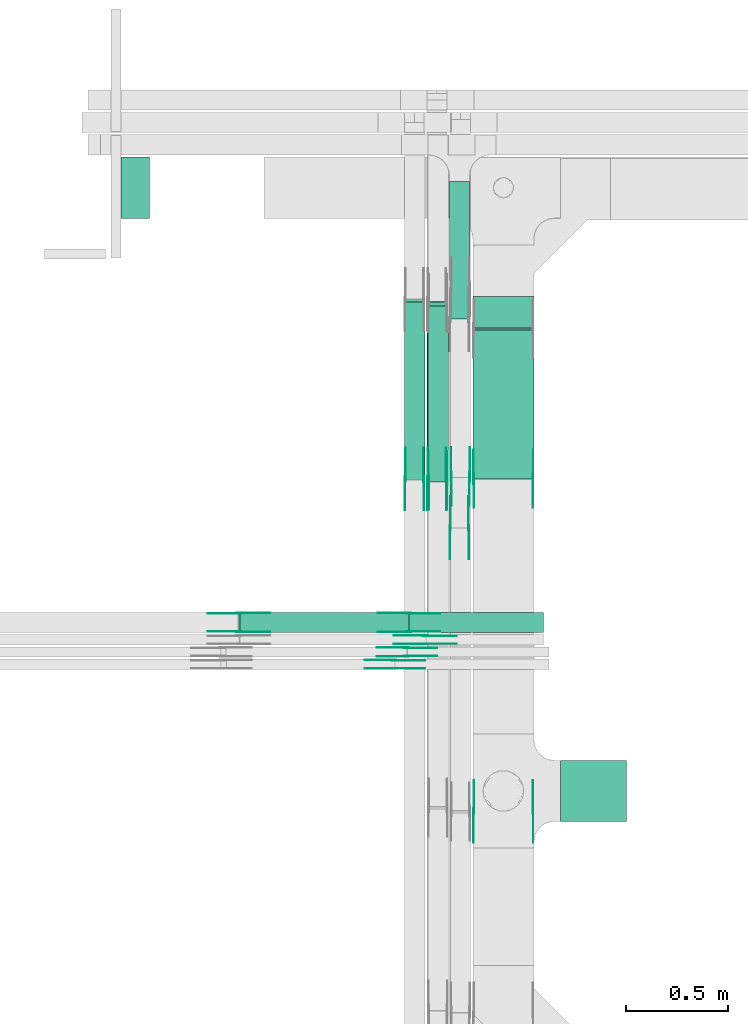
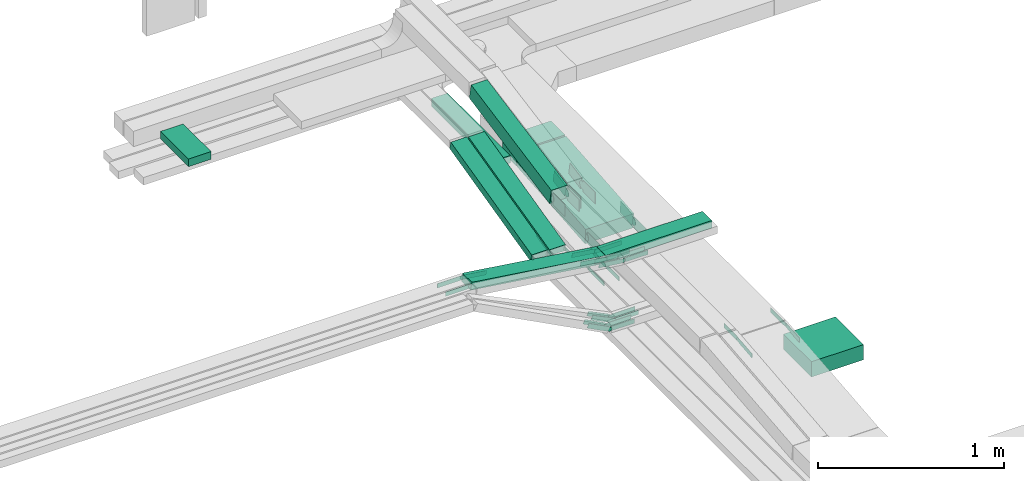
# One storey, part 7 of 32: 48 flow fittings, 10 flow segments.
"""IFC2X3 building model written with IfcOpenShell, lengths in millimetres."""

from ifc_helpers import new_model, entity, si_unit, converted_unit, derived_unit, direction, frame, frame_2d, origin, origin_2d_with_axis, place, context, subcontext, project, spatial, polyline, circle_curve, parameter, trimmed, segment, composite_curve, rectangle, outline, extrude, source, transform, mapped, material, type_object, type_shapes, element, save


model = new_model("IFC2X3")

# Units and contexts
model_context = context("Model", 3, precision=0.01, world=origin(), true_north=direction((6.12303176911189e-17, 1.0)))
body_context = subcontext(model_context, "Body", "Model", "MODEL_VIEW")
ifc_project = project(units=[si_unit("LENGTHUNIT", "METRE", prefix="MILLI"), si_unit("AREAUNIT", "SQUARE_METRE"), si_unit("VOLUMEUNIT", "CUBIC_METRE"), converted_unit("PLANEANGLEUNIT", "DEGREE", entity("IfcRatioMeasure", 0.0174532925199433), si_unit("PLANEANGLEUNIT", "RADIAN"), dimensions=[0, 0, 0, 0, 0, 0, 0]), si_unit("MASSUNIT", "GRAM", prefix="KILO"), derived_unit("MASSDENSITYUNIT", [(si_unit("MASSUNIT", "GRAM", prefix="KILO"), 1), (si_unit("LENGTHUNIT", "METRE"), -3)]), derived_unit("MOMENTOFINERTIAUNIT", [(si_unit("LENGTHUNIT", "METRE"), 4)]), si_unit("TIMEUNIT", "SECOND"), si_unit("FREQUENCYUNIT", "HERTZ"), si_unit("THERMODYNAMICTEMPERATUREUNIT", "DEGREE_CELSIUS"), derived_unit("THERMALTRANSMITTANCEUNIT", [(si_unit("MASSUNIT", "GRAM", prefix="KILO"), 1), (si_unit("THERMODYNAMICTEMPERATUREUNIT", "KELVIN"), -1), (si_unit("TIMEUNIT", "SECOND"), -3)]), derived_unit("VOLUMETRICFLOWRATEUNIT", [(si_unit("LENGTHUNIT", "METRE"), 3), (si_unit("TIMEUNIT", "SECOND"), -1)]), derived_unit("MASSFLOWRATEUNIT", [(si_unit("MASSUNIT", "GRAM", prefix="KILO"), 1), (si_unit("TIMEUNIT", "SECOND"), -1)]), derived_unit("ROTATIONALFREQUENCYUNIT", [(si_unit("TIMEUNIT", "SECOND"), -1)]), si_unit("ELECTRICCURRENTUNIT", "AMPERE"), si_unit("ELECTRICVOLTAGEUNIT", "VOLT"), si_unit("POWERUNIT", "WATT"), si_unit("FORCEUNIT", "NEWTON", prefix="KILO"), si_unit("ILLUMINANCEUNIT", "LUX"), si_unit("LUMINOUSFLUXUNIT", "LUMEN"), si_unit("LUMINOUSINTENSITYUNIT", "CANDELA"), derived_unit("USERDEFINED", [(si_unit("MASSUNIT", "GRAM", prefix="KILO"), -1), (si_unit("LENGTHUNIT", "METRE"), -2), (si_unit("TIMEUNIT", "SECOND"), 3), (si_unit("LUMINOUSFLUXUNIT", "LUMEN"), 1)]), derived_unit("LINEARVELOCITYUNIT", [(si_unit("LENGTHUNIT", "METRE"), 1), (si_unit("TIMEUNIT", "SECOND"), -1)]), si_unit("PRESSUREUNIT", "PASCAL"), derived_unit("USERDEFINED", [(si_unit("LENGTHUNIT", "METRE"), -2), (si_unit("MASSUNIT", "GRAM", prefix="KILO"), 1), (si_unit("TIMEUNIT", "SECOND"), -2)]), derived_unit("LINEARFORCEUNIT", [(si_unit("MASSUNIT", "GRAM", prefix="KILO"), 1), (si_unit("LENGTHUNIT", "METRE"), 1), (si_unit("TIMEUNIT", "SECOND"), -2), (si_unit("LENGTHUNIT", "METRE"), -1)]), derived_unit("PLANARFORCEUNIT", [(si_unit("MASSUNIT", "GRAM", prefix="KILO"), 1), (si_unit("LENGTHUNIT", "METRE"), 1), (si_unit("TIMEUNIT", "SECOND"), -2), (si_unit("LENGTHUNIT", "METRE"), -2)])], contexts=[model_context])

# Site, building, storey
site_placement = place(None, origin())
site = spatial("IfcSite", under=ifc_project, at=site_placement, CompositionType="ELEMENT")
building_placement = place(site_placement, origin())
building = spatial("IfcBuilding", under=site, at=building_placement, CompositionType="ELEMENT")
storey_placement = place(building_placement, frame((0.0, 0.0, 8100.0)))
storey = spatial("IfcBuildingStorey", under=building, at=storey_placement, CompositionType="ELEMENT", Elevation=8100.0)

# Flow segments
cable_carrier_segment_type = type_object("IfcCableCarrierSegmentType", PredefinedType="CABLETRAYSEGMENT")
flow_segment_1_placement = place(storey_placement, frame((18676.05, 11226.25, 2500.0)))
element("IfcFlowSegment", 1, at=flow_segment_1_placement, inside=storey, type_object=cable_carrier_segment_type, context=body_context, shape_type="SweptSolid", body=[
    extrude(rectangle(XDim=322.50000000005, YDim=300.000000000001, at=origin_2d_with_axis()), frame((161.25, 150.0, 0.0)), (0.0, 0.0, 1.0), 99.9999999999989),
])
flow_segment_2_placement = place(storey_placement, frame((18246.05, 13645.88, 2565.0)))
element("IfcFlowSegment", 2, at=flow_segment_2_placement, inside=storey, type_object=cable_carrier_segment_type, context=body_context, shape_type="SweptSolid", body=[
    extrude(rectangle(XDim=152.623116778442, YDim=300.000000000001, at=origin_2d_with_axis()), frame((150.0, 76.31, 0.0), z_axis=(0.0, 0.0, 1.0), x_axis=(0.0, 1.0, 0.0)), (0.0, 0.0, 1.0), 100.000000000001),
])
flow_segment_3_placement = place(storey_placement, frame((18246.05, 12903.96, 2500.49)))
element("IfcFlowSegment", 3, at=flow_segment_3_placement, inside=storey, type_object=cable_carrier_segment_type, context=body_context, shape_type="SweptSolid", body=[
    extrude(rectangle(XDim=99.9999999999982, YDim=733.623391012319, at=frame_2d((0.0, 0.0), x_axis=(0.0, 1.0))), frame((0.0, 369.78, 82.01), z_axis=(1.0, 0.0, 0.0), x_axis=(0.0, -0.996138692653759, -0.0877935361974901)), (0.0, 0.0, 1.0), 300.000000000001),
])
flow_segment_4_placement = place(storey_placement, frame((18131.01, 13688.09, 2565.34)))
element("IfcFlowSegment", 4, at=flow_segment_4_placement, inside=storey, type_object=cable_carrier_segment_type, context=body_context, shape_type="SweptSolid", body=[
    extrude(rectangle(XDim=674.18746787465, YDim=99.9999999999989, at=origin_2d_with_axis()), frame((50.0, 337.09, 0.0), z_axis=(0.0, 0.0, 1.0), x_axis=(0.0, -1.0, 0.0)), (0.0, 0.0, 1.0), 50.0000000000016),
])
flow_segment_5_placement = place(storey_placement, frame((17911.01, 12903.42, 2501.79)))
element("IfcFlowSegment", 5, at=flow_segment_5_placement, inside=storey, type_object=cable_carrier_segment_type, context=body_context, shape_type="SweptSolid", body=[
    extrude(rectangle(XDim=50.0000000000038, YDim=895.216651992344, at=frame_2d((0.0, 0.0), x_axis=(0.0, 1.0))), frame((0.0, 440.72, 130.71), z_axis=(1.0, 0.0, 0.0), x_axis=(0.0, 0.971320023080272, 0.237775971795595)), (0.0, 0.0, 1.0), 99.9999999999968),
])
flow_segment_6_placement = place(storey_placement, frame((18021.01, 12903.42, 2497.25)))
element("IfcFlowSegment", 6, at=flow_segment_6_placement, inside=storey, type_object=cable_carrier_segment_type, context=body_context, shape_type="SweptSolid", body=[
    extrude(rectangle(XDim=49.9999999999981, YDim=896.294412020018, at=frame_2d((0.0, 0.0), x_axis=(0.0, 1.0))), frame((0.0, 441.24, 130.84), z_axis=(1.0, 0.0, 0.0), x_axis=(0.0, 0.971320023080293, 0.237775971795511)), (0.0, 0.0, 1.0), 99.9999999999989),
])
flow_segment_7_placement = place(storey_placement, frame((16522.31, 14182.28, 2840.02)))
element("IfcFlowSegment", 7, at=flow_segment_7_placement, inside=storey, type_object=cable_carrier_segment_type, context=body_context, shape_type="SweptSolid", body=[
    extrude(rectangle(XDim=140.194233872036, YDim=300.000000000001, at=origin_2d_with_axis()), frame((70.1, 150.0, 0.0), z_axis=(0.0, 0.0, 1.0), x_axis=(-1.0, 0.0, 0.0)), (0.0, 0.0, 1.0), 50.0000000000016),
])
flow_segment_8_placement = place(storey_placement, frame((18026.05, 12892.26, 2842.16)))
element("IfcFlowSegment", 8, at=flow_segment_8_placement, inside=storey, type_object=cable_carrier_segment_type, context=body_context, shape_type="SweptSolid", body=[
    extrude(rectangle(XDim=100.000000000003, YDim=99.9999999999989, at=origin_2d_with_axis()), frame((50.0, 9.67, 49.06), z_axis=(0.0, 0.981126269625997, 0.193368154176885), x_axis=(0.0, -0.193368154176885, 0.981126269625997)), (0.0, 0.0, 1.0), 877.56328106953),
])
flow_segment_9_placement = place(storey_placement, frame((17936.24, 12151.75, 2943.75)))
element("IfcFlowSegment", 9, at=flow_segment_9_placement, inside=storey, type_object=cable_carrier_segment_type, context=body_context, shape_type="SweptSolid", body=[
    extrude(rectangle(XDim=656.987690793579, YDim=99.9999999999989, at=origin_2d_with_axis()), frame((328.49, 50.0, 0.0), z_axis=(0.0, 0.0, 1.0), x_axis=(-1.0, 0.0, 0.0)), (0.0, 0.0, 1.0), 49.9999999999995),
])
flow_segment_10_placement = place(storey_placement, frame((17099.11, 12151.75, 2944.4)))
element("IfcFlowSegment", 10, at=flow_segment_10_placement, inside=storey, type_object=cable_carrier_segment_type, context=body_context, shape_type="SweptSolid", body=[
    extrude(rectangle(XDim=49.9999999999989, YDim=99.9999999999989, at=origin_2d_with_axis()), frame((3.45, 50.0, 140.18), z_axis=(0.990416209044974, 0.0, -0.138114926278746), x_axis=(0.138114926278746, 0.0, 0.990416209044974)), (0.0, 0.0, 1.0), 835.687573909055),
])

# Flow fittings
ifc_material = material(Name="G")
cable_carrier_fitting_type_1 = type_object("IfcCableCarrierFittingType", PredefinedType="NOTDEFINED", material=ifc_material)
shared_shape_1 = source(origin(), body_context, "Body", "SweptSolid", [
    extrude(outline(composite_curve([segment(trimmed(circle_curve(frame_2d((-44.59, 0.0), x_axis=(1.0, 0.0)), 12.5), [parameter(90.0000000000007)], [parameter(270.0)], True, "PARAMETER"), True, "CONTINUOUS"), segment(polyline([(-44.59, -12.5), (-33.09, -12.5)]), True, "CONTINUOUS"), segment(polyline([(-33.09, -12.5), (-31.23, -14.5)]), True, "CONTINUOUS"), segment(polyline([(-31.23, -14.5), (108.91, -14.5)]), True, "CONTINUOUS"), segment(polyline([(108.91, -14.5), (108.91, 14.5)]), True, "CONTINUOUS"), segment(polyline([(108.91, 14.5), (-31.23, 14.5)]), True, "CONTINUOUS"), segment(polyline([(-31.23, 14.5), (-33.09, 12.5)]), True, "CONTINUOUS"), segment(polyline([(-33.09, 12.5), (-44.59, 12.5)]), True, "CONTINUOUS")], self_intersect=False)), frame((44.59, 0.0, 0.0), z_axis=(0.0, 0.0, -1.0), x_axis=(1.0, 0.0, 0.0)), (0.0, 0.0, -1.0), 2.0),
])
type_shapes(cable_carrier_fitting_type_1, [shared_shape_1])
flow_fitting_1_placement = place(storey_placement, frame((18541.51, 11275.78, 2865.02), z_axis=(1.0, 0.0, 0.0), x_axis=(0.0, -0.994974854702737, -0.10012511427842)))
element("IfcFlowFitting", 11, at=flow_fitting_1_placement, inside=storey, type_object=cable_carrier_fitting_type_1, material=ifc_material, context=body_context, shape_type="MappedRepresentation", body=[
    mapped(shared_shape_1, transform((0.0, 0.0, 0.0), scale=1.0)),
])
cable_carrier_fitting_type_2 = type_object("IfcCableCarrierFittingType", PredefinedType="NOTDEFINED", material=ifc_material)
type_shapes(cable_carrier_fitting_type_2, [shared_shape_1])
flow_fitting_2_placement = place(storey_placement, frame((18252.59, 11275.78, 2865.02), z_axis=(-1.0, 0.0, 0.0), x_axis=(0.0, 1.0, 0.0)))
element("IfcFlowFitting", 12, at=flow_fitting_2_placement, inside=storey, type_object=cable_carrier_fitting_type_2, material=ifc_material, context=body_context, shape_type="MappedRepresentation", body=[
    mapped(shared_shape_1, transform((0.0, 0.0, 0.0), scale=1.0)),
])
flow_fitting_3_placement = place(storey_placement, frame((17915.55, 12905.0, 2525.0), z_axis=(-1.0, 0.0, 0.0), x_axis=(0.0, -1.0, 0.0)))
element("IfcFlowFitting", 13, at=flow_fitting_3_placement, inside=storey, type_object=cable_carrier_fitting_type_1, material=ifc_material, context=body_context, shape_type="MappedRepresentation", body=[
    mapped(shared_shape_1, transform((0.0, 0.0, 0.0), scale=1.0)),
])
flow_fitting_4_placement = place(storey_placement, frame((18004.47, 12905.0, 2525.0), z_axis=(1.0, 0.0, 0.0), x_axis=(0.0, 0.971320023080276, 0.237775971795579)))
element("IfcFlowFitting", 14, at=flow_fitting_4_placement, inside=storey, type_object=cable_carrier_fitting_type_2, material=ifc_material, context=body_context, shape_type="MappedRepresentation", body=[
    mapped(shared_shape_1, transform((0.0, 0.0, 0.0), scale=1.0)),
])
flow_fitting_5_placement = place(storey_placement, frame((18025.55, 12905.0, 2520.47), z_axis=(-1.0, 0.0, 0.0), x_axis=(0.0, -1.0, 0.0)))
element("IfcFlowFitting", 15, at=flow_fitting_5_placement, inside=storey, type_object=cable_carrier_fitting_type_1, material=ifc_material, context=body_context, shape_type="MappedRepresentation", body=[
    mapped(shared_shape_1, transform((0.0, 0.0, 0.0), scale=1.0)),
])
flow_fitting_6_placement = place(storey_placement, frame((18114.47, 12905.0, 2520.47), z_axis=(1.0, 0.0, 0.0), x_axis=(0.0, 0.971320023080296, 0.237775971795496)))
element("IfcFlowFitting", 16, at=flow_fitting_6_placement, inside=storey, type_object=cable_carrier_fitting_type_2, material=ifc_material, context=body_context, shape_type="MappedRepresentation", body=[
    mapped(shared_shape_1, transform((0.0, 0.0, 0.0), scale=1.0)),
])
flow_fitting_7_placement = place(storey_placement, frame((18135.55, 12665.0, 2520.32), z_axis=(-1.0, 0.0, 0.0), x_axis=(0.0, -1.0, 0.0)))
element("IfcFlowFitting", 17, at=flow_fitting_7_placement, inside=storey, type_object=cable_carrier_fitting_type_1, material=ifc_material, context=body_context, shape_type="MappedRepresentation", body=[
    mapped(shared_shape_1, transform((0.0, 0.0, 0.0), scale=1.0)),
])
flow_fitting_8_placement = place(storey_placement, frame((18224.47, 12665.0, 2520.32), z_axis=(1.0, 0.0, 0.0), x_axis=(0.0, 0.997656992775832, 0.0684143608132392)))
element("IfcFlowFitting", 18, at=flow_fitting_8_placement, inside=storey, type_object=cable_carrier_fitting_type_2, material=ifc_material, context=body_context, shape_type="MappedRepresentation", body=[
    mapped(shared_shape_1, transform((0.0, 0.0, 0.0), scale=1.0)),
])
flow_fitting_9_placement = place(storey_placement, frame((18013.23, 12137.21, 2968.75), z_axis=(0.0, 1.0, 0.0), x_axis=(-0.992001694765699, 0.0, 0.126224552215409)))
element("IfcFlowFitting", 19, at=flow_fitting_9_placement, inside=storey, type_object=cable_carrier_fitting_type_1, material=ifc_material, context=body_context, shape_type="MappedRepresentation", body=[
    mapped(shared_shape_1, transform((0.0, 0.0, 0.0), scale=1.0)),
])
flow_fitting_10_placement = place(storey_placement, frame((18013.23, 12098.29, 2968.75), z_axis=(0.0, -1.0, 0.0), x_axis=(1.0, 0.0, 0.0)))
element("IfcFlowFitting", 20, at=flow_fitting_10_placement, inside=storey, type_object=cable_carrier_fitting_type_2, material=ifc_material, context=body_context, shape_type="MappedRepresentation", body=[
    mapped(shared_shape_1, transform((0.0, 0.0, 0.0), scale=1.0)),
])
flow_fitting_11_placement = place(storey_placement, frame((17933.23, 12247.21, 2968.75), z_axis=(0.0, 1.0, 0.0), x_axis=(-0.990416209044951, 0.0, 0.138114926278904)))
element("IfcFlowFitting", 21, at=flow_fitting_11_placement, inside=storey, type_object=cable_carrier_fitting_type_1, material=ifc_material, context=body_context, shape_type="MappedRepresentation", body=[
    mapped(shared_shape_1, transform((0.0, 0.0, 0.0), scale=1.0)),
])
flow_fitting_12_placement = place(storey_placement, frame((17933.23, 12158.29, 2968.75), z_axis=(0.0, -1.0, 0.0), x_axis=(1.0, 0.0, 0.0)))
element("IfcFlowFitting", 22, at=flow_fitting_12_placement, inside=storey, type_object=cable_carrier_fitting_type_2, material=ifc_material, context=body_context, shape_type="MappedRepresentation", body=[
    mapped(shared_shape_1, transform((0.0, 0.0, 0.0), scale=1.0)),
])
flow_fitting_13_placement = place(storey_placement, frame((17099.58, 12247.21, 3085.0), z_axis=(0.0, 1.0, 0.0), x_axis=(0.990416209044951, 0.0, -0.138114926278904)))
element("IfcFlowFitting", 23, at=flow_fitting_13_placement, inside=storey, type_object=cable_carrier_fitting_type_1, material=ifc_material, context=body_context, shape_type="MappedRepresentation", body=[
    mapped(shared_shape_1, transform((0.0, 0.0, 0.0), scale=1.0)),
])
flow_fitting_14_placement = place(storey_placement, frame((17099.58, 12158.29, 3085.0), z_axis=(0.0, -1.0, 0.0), x_axis=(-1.0, 0.0, 0.0)))
element("IfcFlowFitting", 24, at=flow_fitting_14_placement, inside=storey, type_object=cable_carrier_fitting_type_2, material=ifc_material, context=body_context, shape_type="MappedRepresentation", body=[
    mapped(shared_shape_1, transform((0.0, 0.0, 0.0), scale=1.0)),
])
flow_fitting_15_placement = place(storey_placement, frame((17859.58, 12017.21, 2645.0), z_axis=(0.0, 1.0, 0.0), x_axis=(-0.885831535280083, 0.0, 0.464006994670695)))
element("IfcFlowFitting", 25, at=flow_fitting_15_placement, inside=storey, type_object=cable_carrier_fitting_type_1, material=ifc_material, context=body_context, shape_type="MappedRepresentation", body=[
    mapped(shared_shape_1, transform((0.0, 0.0, 0.0), scale=1.0)),
])
flow_fitting_16_placement = place(storey_placement, frame((17859.58, 11978.29, 2645.0), z_axis=(0.0, -1.0, 0.0), x_axis=(1.0, 0.0, 0.0)))
element("IfcFlowFitting", 26, at=flow_fitting_16_placement, inside=storey, type_object=cable_carrier_fitting_type_2, material=ifc_material, context=body_context, shape_type="MappedRepresentation", body=[
    mapped(shared_shape_1, transform((0.0, 0.0, 0.0), scale=1.0)),
])
flow_fitting_17_placement = place(storey_placement, frame((17919.58, 12077.21, 2645.0), z_axis=(0.0, 1.0, 0.0), x_axis=(-0.898384360919165, 0.0, 0.439210132005016)))
element("IfcFlowFitting", 27, at=flow_fitting_17_placement, inside=storey, type_object=cable_carrier_fitting_type_1, material=ifc_material, context=body_context, shape_type="MappedRepresentation", body=[
    mapped(shared_shape_1, transform((0.0, 0.0, 0.0), scale=1.0)),
])
flow_fitting_18_placement = place(storey_placement, frame((17919.58, 12038.29, 2645.0), z_axis=(0.0, -1.0, 0.0), x_axis=(1.0, 0.0, 0.0)))
element("IfcFlowFitting", 28, at=flow_fitting_18_placement, inside=storey, type_object=cable_carrier_fitting_type_2, material=ifc_material, context=body_context, shape_type="MappedRepresentation", body=[
    mapped(shared_shape_1, transform((0.0, 0.0, 0.0), scale=1.0)),
])
cable_carrier_fitting_type_3 = type_object("IfcCableCarrierFittingType", PredefinedType="NOTDEFINED", material=ifc_material)
shared_shape_2 = source(origin(), body_context, "Body", "SweptSolid", [
    extrude(outline(composite_curve([segment(trimmed(circle_curve(frame_2d((-44.59, 0.0), x_axis=(1.0, 0.0)), 12.5), [parameter(90.0000000000007)], [parameter(270.0)], True, "PARAMETER"), True, "CONTINUOUS"), segment(polyline([(-44.59, -12.5), (-33.09, -12.5)]), True, "CONTINUOUS"), segment(polyline([(-33.09, -12.5), (-31.23, -14.5)]), True, "CONTINUOUS"), segment(polyline([(-31.23, -14.5), (108.91, -14.5)]), True, "CONTINUOUS"), segment(polyline([(108.91, -14.5), (108.91, 14.5)]), True, "CONTINUOUS"), segment(polyline([(108.91, 14.5), (-31.23, 14.5)]), True, "CONTINUOUS"), segment(polyline([(-31.23, 14.5), (-33.09, 12.5)]), True, "CONTINUOUS"), segment(polyline([(-33.09, 12.5), (-44.59, 12.5)]), True, "CONTINUOUS")], self_intersect=False)), frame((44.59, 0.0, 0.0)), (0.0, 0.0, 1.0), 2.0),
])
type_shapes(cable_carrier_fitting_type_3, [shared_shape_2])
flow_fitting_19_placement = place(storey_placement, frame((18250.59, 11275.78, 2865.02), z_axis=(-1.0, 0.0, 0.0), x_axis=(0.0, -0.994974854702737, -0.10012511427842)))
element("IfcFlowFitting", 29, at=flow_fitting_19_placement, inside=storey, type_object=cable_carrier_fitting_type_3, material=ifc_material, context=body_context, shape_type="MappedRepresentation", body=[
    mapped(shared_shape_2, transform((0.0, 0.0, 0.0), scale=1.0)),
])
cable_carrier_fitting_type_4 = type_object("IfcCableCarrierFittingType", PredefinedType="NOTDEFINED", material=ifc_material)
type_shapes(cable_carrier_fitting_type_4, [shared_shape_2])
flow_fitting_20_placement = place(storey_placement, frame((18539.51, 11275.78, 2865.02), z_axis=(1.0, 0.0, 0.0), x_axis=(0.0, 1.0, 0.0)))
element("IfcFlowFitting", 30, at=flow_fitting_20_placement, inside=storey, type_object=cable_carrier_fitting_type_4, material=ifc_material, context=body_context, shape_type="MappedRepresentation", body=[
    mapped(shared_shape_2, transform((0.0, 0.0, 0.0), scale=1.0)),
])
flow_fitting_21_placement = place(storey_placement, frame((18006.47, 12905.0, 2525.0), z_axis=(1.0, 0.0, 0.0), x_axis=(0.0, -1.0, 0.0)))
element("IfcFlowFitting", 31, at=flow_fitting_21_placement, inside=storey, type_object=cable_carrier_fitting_type_3, material=ifc_material, context=body_context, shape_type="MappedRepresentation", body=[
    mapped(shared_shape_2, transform((0.0, 0.0, 0.0), scale=1.0)),
])
flow_fitting_22_placement = place(storey_placement, frame((17917.55, 12905.0, 2525.0), z_axis=(-1.0, 0.0, 0.0), x_axis=(0.0, 0.971320023080276, 0.237775971795579)))
element("IfcFlowFitting", 32, at=flow_fitting_22_placement, inside=storey, type_object=cable_carrier_fitting_type_4, material=ifc_material, context=body_context, shape_type="MappedRepresentation", body=[
    mapped(shared_shape_2, transform((0.0, 0.0, 0.0), scale=1.0)),
])
flow_fitting_23_placement = place(storey_placement, frame((18116.47, 12905.0, 2520.47), z_axis=(1.0, 0.0, 0.0), x_axis=(0.0, -1.0, 0.0)))
element("IfcFlowFitting", 33, at=flow_fitting_23_placement, inside=storey, type_object=cable_carrier_fitting_type_3, material=ifc_material, context=body_context, shape_type="MappedRepresentation", body=[
    mapped(shared_shape_2, transform((0.0, 0.0, 0.0), scale=1.0)),
])
flow_fitting_24_placement = place(storey_placement, frame((18027.55, 12905.0, 2520.47), z_axis=(-1.0, 0.0, 0.0), x_axis=(0.0, 0.971320023080296, 0.237775971795496)))
element("IfcFlowFitting", 34, at=flow_fitting_24_placement, inside=storey, type_object=cable_carrier_fitting_type_4, material=ifc_material, context=body_context, shape_type="MappedRepresentation", body=[
    mapped(shared_shape_2, transform((0.0, 0.0, 0.0), scale=1.0)),
])
flow_fitting_25_placement = place(storey_placement, frame((18226.47, 12665.0, 2520.32), z_axis=(1.0, 0.0, 0.0), x_axis=(0.0, -1.0, 0.0)))
element("IfcFlowFitting", 35, at=flow_fitting_25_placement, inside=storey, type_object=cable_carrier_fitting_type_3, material=ifc_material, context=body_context, shape_type="MappedRepresentation", body=[
    mapped(shared_shape_2, transform((0.0, 0.0, 0.0), scale=1.0)),
])
flow_fitting_26_placement = place(storey_placement, frame((18137.55, 12665.0, 2520.32), z_axis=(-1.0, 0.0, 0.0), x_axis=(0.0, 0.997656992775832, 0.0684143608132392)))
element("IfcFlowFitting", 36, at=flow_fitting_26_placement, inside=storey, type_object=cable_carrier_fitting_type_4, material=ifc_material, context=body_context, shape_type="MappedRepresentation", body=[
    mapped(shared_shape_2, transform((0.0, 0.0, 0.0), scale=1.0)),
])
flow_fitting_27_placement = place(storey_placement, frame((18013.23, 12096.29, 2968.75), z_axis=(0.0, -1.0, 0.0), x_axis=(-0.992001694765699, 0.0, 0.126224552215409)))
element("IfcFlowFitting", 37, at=flow_fitting_27_placement, inside=storey, type_object=cable_carrier_fitting_type_3, material=ifc_material, context=body_context, shape_type="MappedRepresentation", body=[
    mapped(shared_shape_2, transform((0.0, 0.0, 0.0), scale=1.0)),
])
flow_fitting_28_placement = place(storey_placement, frame((18013.23, 12135.21, 2968.75), z_axis=(0.0, 1.0, 0.0), x_axis=(1.0, 0.0, 0.0)))
element("IfcFlowFitting", 38, at=flow_fitting_28_placement, inside=storey, type_object=cable_carrier_fitting_type_4, material=ifc_material, context=body_context, shape_type="MappedRepresentation", body=[
    mapped(shared_shape_2, transform((0.0, 0.0, 0.0), scale=1.0)),
])
flow_fitting_29_placement = place(storey_placement, frame((17933.23, 12156.29, 2968.75), z_axis=(0.0, -1.0, 0.0), x_axis=(-0.990416209044951, 0.0, 0.138114926278904)))
element("IfcFlowFitting", 39, at=flow_fitting_29_placement, inside=storey, type_object=cable_carrier_fitting_type_3, material=ifc_material, context=body_context, shape_type="MappedRepresentation", body=[
    mapped(shared_shape_2, transform((0.0, 0.0, 0.0), scale=1.0)),
])
flow_fitting_30_placement = place(storey_placement, frame((17933.23, 12245.21, 2968.75), z_axis=(0.0, 1.0, 0.0), x_axis=(1.0, 0.0, 0.0)))
element("IfcFlowFitting", 40, at=flow_fitting_30_placement, inside=storey, type_object=cable_carrier_fitting_type_4, material=ifc_material, context=body_context, shape_type="MappedRepresentation", body=[
    mapped(shared_shape_2, transform((0.0, 0.0, 0.0), scale=1.0)),
])
flow_fitting_31_placement = place(storey_placement, frame((17099.58, 12156.29, 3085.0), z_axis=(0.0, -1.0, 0.0), x_axis=(0.990416209044951, 0.0, -0.138114926278904)))
element("IfcFlowFitting", 41, at=flow_fitting_31_placement, inside=storey, type_object=cable_carrier_fitting_type_3, material=ifc_material, context=body_context, shape_type="MappedRepresentation", body=[
    mapped(shared_shape_2, transform((0.0, 0.0, 0.0), scale=1.0)),
])
flow_fitting_32_placement = place(storey_placement, frame((17099.58, 12245.21, 3085.0), z_axis=(0.0, 1.0, 0.0), x_axis=(-1.0, 0.0, 0.0)))
element("IfcFlowFitting", 42, at=flow_fitting_32_placement, inside=storey, type_object=cable_carrier_fitting_type_4, material=ifc_material, context=body_context, shape_type="MappedRepresentation", body=[
    mapped(shared_shape_2, transform((0.0, 0.0, 0.0), scale=1.0)),
])
flow_fitting_33_placement = place(storey_placement, frame((17859.58, 11976.29, 2645.0), z_axis=(0.0, -1.0, 0.0), x_axis=(-0.885831535280083, 0.0, 0.464006994670695)))
element("IfcFlowFitting", 43, at=flow_fitting_33_placement, inside=storey, type_object=cable_carrier_fitting_type_3, material=ifc_material, context=body_context, shape_type="MappedRepresentation", body=[
    mapped(shared_shape_2, transform((0.0, 0.0, 0.0), scale=1.0)),
])
flow_fitting_34_placement = place(storey_placement, frame((17859.58, 12015.21, 2645.0), z_axis=(0.0, 1.0, 0.0), x_axis=(1.0, 0.0, 0.0)))
element("IfcFlowFitting", 44, at=flow_fitting_34_placement, inside=storey, type_object=cable_carrier_fitting_type_4, material=ifc_material, context=body_context, shape_type="MappedRepresentation", body=[
    mapped(shared_shape_2, transform((0.0, 0.0, 0.0), scale=1.0)),
])
flow_fitting_35_placement = place(storey_placement, frame((17919.58, 12036.29, 2645.0), z_axis=(0.0, -1.0, 0.0), x_axis=(-0.898384360919165, 0.0, 0.439210132005016)))
element("IfcFlowFitting", 45, at=flow_fitting_35_placement, inside=storey, type_object=cable_carrier_fitting_type_3, material=ifc_material, context=body_context, shape_type="MappedRepresentation", body=[
    mapped(shared_shape_2, transform((0.0, 0.0, 0.0), scale=1.0)),
])
flow_fitting_36_placement = place(storey_placement, frame((17919.58, 12075.21, 2645.0), z_axis=(0.0, 1.0, 0.0), x_axis=(1.0, 0.0, 0.0)))
element("IfcFlowFitting", 46, at=flow_fitting_36_placement, inside=storey, type_object=cable_carrier_fitting_type_4, material=ifc_material, context=body_context, shape_type="MappedRepresentation", body=[
    mapped(shared_shape_2, transform((0.0, 0.0, 0.0), scale=1.0)),
])
cable_carrier_fitting_type_5 = type_object("IfcCableCarrierFittingType", PredefinedType="NOTDEFINED", material=ifc_material)
shared_shape_3 = source(origin(), body_context, "Body", "SweptSolid", [
    extrude(outline(composite_curve([segment(trimmed(circle_curve(frame_2d((-41.47, 0.0), x_axis=(1.0, 0.0)), 25.0), [parameter(90.0000000000007)], [parameter(270.0)], True, "PARAMETER"), True, "CONTINUOUS"), segment(polyline([(-41.47, -25.0), (-29.97, -25.0)]), True, "CONTINUOUS"), segment(polyline([(-29.97, -25.0), (-28.1, -38.5)]), True, "CONTINUOUS"), segment(polyline([(-28.1, -38.5), (99.53, -38.5)]), True, "CONTINUOUS"), segment(polyline([(99.53, -38.5), (99.53, 38.5)]), True, "CONTINUOUS"), segment(polyline([(99.53, 38.5), (-28.1, 38.5)]), True, "CONTINUOUS"), segment(polyline([(-28.1, 38.5), (-29.97, 25.0)]), True, "CONTINUOUS"), segment(polyline([(-29.97, 25.0), (-41.47, 25.0)]), True, "CONTINUOUS")], self_intersect=False)), frame((41.47, 0.0, 0.0), z_axis=(0.0, 0.0, -1.0), x_axis=(1.0, 0.0, 0.0)), (0.0, 0.0, -1.0), 2.0),
])
type_shapes(cable_carrier_fitting_type_5, [shared_shape_3])
flow_fitting_37_placement = place(storey_placement, frame((18541.51, 12904.99, 2550.0), z_axis=(1.0, 0.0, 0.0), x_axis=(0.0, 0.996138692653759, 0.0877935361974902)))
element("IfcFlowFitting", 47, at=flow_fitting_37_placement, inside=storey, type_object=cable_carrier_fitting_type_5, material=ifc_material, context=body_context, shape_type="MappedRepresentation", body=[
    mapped(shared_shape_3, transform((0.0, 0.0, 0.0), scale=1.0)),
])
cable_carrier_fitting_type_6 = type_object("IfcCableCarrierFittingType", PredefinedType="NOTDEFINED", material=ifc_material)
type_shapes(cable_carrier_fitting_type_6, [shared_shape_3])
flow_fitting_38_placement = place(storey_placement, frame((18252.59, 12904.99, 2550.0), z_axis=(-1.0, 0.0, 0.0), x_axis=(0.0, -1.0, 0.0)))
element("IfcFlowFitting", 48, at=flow_fitting_38_placement, inside=storey, type_object=cable_carrier_fitting_type_6, material=ifc_material, context=body_context, shape_type="MappedRepresentation", body=[
    mapped(shared_shape_3, transform((0.0, 0.0, 0.0), scale=1.0)),
])
flow_fitting_39_placement = place(storey_placement, frame((18231.51, 12915.78, 2890.0), z_axis=(1.0, 0.0, 0.0), x_axis=(0.0, 0.983372782908371, 0.181598375089224)))
element("IfcFlowFitting", 49, at=flow_fitting_39_placement, inside=storey, type_object=cable_carrier_fitting_type_5, material=ifc_material, context=body_context, shape_type="MappedRepresentation", body=[
    mapped(shared_shape_3, transform((0.0, 0.0, 0.0), scale=1.0)),
])
flow_fitting_40_placement = place(storey_placement, frame((18142.59, 12915.78, 2890.0), z_axis=(-1.0, 0.0, 0.0), x_axis=(0.0, -1.0, 0.0)))
element("IfcFlowFitting", 50, at=flow_fitting_40_placement, inside=storey, type_object=cable_carrier_fitting_type_6, material=ifc_material, context=body_context, shape_type="MappedRepresentation", body=[
    mapped(shared_shape_3, transform((0.0, 0.0, 0.0), scale=1.0)),
])
flow_fitting_41_placement = place(storey_placement, frame((18121.51, 12895.78, 2890.0), z_axis=(1.0, 0.0, 0.0), x_axis=(0.0, 0.981126269625946, 0.193368154177143)))
element("IfcFlowFitting", 51, at=flow_fitting_41_placement, inside=storey, type_object=cable_carrier_fitting_type_5, material=ifc_material, context=body_context, shape_type="MappedRepresentation", body=[
    mapped(shared_shape_3, transform((0.0, 0.0, 0.0), scale=1.0)),
])
flow_fitting_42_placement = place(storey_placement, frame((18032.59, 12895.78, 2890.0), z_axis=(-1.0, 0.0, 0.0), x_axis=(0.0, -1.0, 0.0)))
element("IfcFlowFitting", 52, at=flow_fitting_42_placement, inside=storey, type_object=cable_carrier_fitting_type_6, material=ifc_material, context=body_context, shape_type="MappedRepresentation", body=[
    mapped(shared_shape_3, transform((0.0, 0.0, 0.0), scale=1.0)),
])
cable_carrier_fitting_type_7 = type_object("IfcCableCarrierFittingType", PredefinedType="NOTDEFINED", material=ifc_material)
shared_shape_4 = source(origin(), body_context, "Body", "SweptSolid", [
    extrude(outline(composite_curve([segment(trimmed(circle_curve(frame_2d((-41.47, 0.0), x_axis=(1.0, 0.0)), 25.0), [parameter(90.0000000000007)], [parameter(270.0)], True, "PARAMETER"), True, "CONTINUOUS"), segment(polyline([(-41.47, -25.0), (-29.97, -25.0)]), True, "CONTINUOUS"), segment(polyline([(-29.97, -25.0), (-28.1, -38.5)]), True, "CONTINUOUS"), segment(polyline([(-28.1, -38.5), (99.53, -38.5)]), True, "CONTINUOUS"), segment(polyline([(99.53, -38.5), (99.53, 38.5)]), True, "CONTINUOUS"), segment(polyline([(99.53, 38.5), (-28.1, 38.5)]), True, "CONTINUOUS"), segment(polyline([(-28.1, 38.5), (-29.97, 25.0)]), True, "CONTINUOUS"), segment(polyline([(-29.97, 25.0), (-41.47, 25.0)]), True, "CONTINUOUS")], self_intersect=False)), frame((41.47, 0.0, 0.0)), (0.0, 0.0, 1.0), 2.0),
])
type_shapes(cable_carrier_fitting_type_7, [shared_shape_4])
flow_fitting_43_placement = place(storey_placement, frame((18250.59, 12904.99, 2550.0), z_axis=(-1.0, 0.0, 0.0), x_axis=(0.0, 0.996138692653759, 0.0877935361974902)))
element("IfcFlowFitting", 53, at=flow_fitting_43_placement, inside=storey, type_object=cable_carrier_fitting_type_7, material=ifc_material, context=body_context, shape_type="MappedRepresentation", body=[
    mapped(shared_shape_4, transform((0.0, 0.0, 0.0), scale=1.0)),
])
cable_carrier_fitting_type_8 = type_object("IfcCableCarrierFittingType", PredefinedType="NOTDEFINED", material=ifc_material)
type_shapes(cable_carrier_fitting_type_8, [shared_shape_4])
flow_fitting_44_placement = place(storey_placement, frame((18539.51, 12904.99, 2550.0), z_axis=(1.0, 0.0, 0.0), x_axis=(0.0, -1.0, 0.0)))
element("IfcFlowFitting", 54, at=flow_fitting_44_placement, inside=storey, type_object=cable_carrier_fitting_type_8, material=ifc_material, context=body_context, shape_type="MappedRepresentation", body=[
    mapped(shared_shape_4, transform((0.0, 0.0, 0.0), scale=1.0)),
])
flow_fitting_45_placement = place(storey_placement, frame((18140.59, 12915.78, 2890.0), z_axis=(-1.0, 0.0, 0.0), x_axis=(0.0, 0.983372782908371, 0.181598375089224)))
element("IfcFlowFitting", 55, at=flow_fitting_45_placement, inside=storey, type_object=cable_carrier_fitting_type_7, material=ifc_material, context=body_context, shape_type="MappedRepresentation", body=[
    mapped(shared_shape_4, transform((0.0, 0.0, 0.0), scale=1.0)),
])
flow_fitting_46_placement = place(storey_placement, frame((18229.51, 12915.78, 2890.0), z_axis=(1.0, 0.0, 0.0), x_axis=(0.0, -1.0, 0.0)))
element("IfcFlowFitting", 56, at=flow_fitting_46_placement, inside=storey, type_object=cable_carrier_fitting_type_8, material=ifc_material, context=body_context, shape_type="MappedRepresentation", body=[
    mapped(shared_shape_4, transform((0.0, 0.0, 0.0), scale=1.0)),
])
flow_fitting_47_placement = place(storey_placement, frame((18030.59, 12895.78, 2890.0), z_axis=(-1.0, 0.0, 0.0), x_axis=(0.0, 0.981126269625946, 0.193368154177143)))
element("IfcFlowFitting", 57, at=flow_fitting_47_placement, inside=storey, type_object=cable_carrier_fitting_type_7, material=ifc_material, context=body_context, shape_type="MappedRepresentation", body=[
    mapped(shared_shape_4, transform((0.0, 0.0, 0.0), scale=1.0)),
])
flow_fitting_48_placement = place(storey_placement, frame((18119.51, 12895.78, 2890.0), z_axis=(1.0, 0.0, 0.0), x_axis=(0.0, -1.0, 0.0)))
element("IfcFlowFitting", 58, at=flow_fitting_48_placement, inside=storey, type_object=cable_carrier_fitting_type_8, material=ifc_material, context=body_context, shape_type="MappedRepresentation", body=[
    mapped(shared_shape_4, transform((0.0, 0.0, 0.0), scale=1.0)),
])

save(model, "model.ifc")
